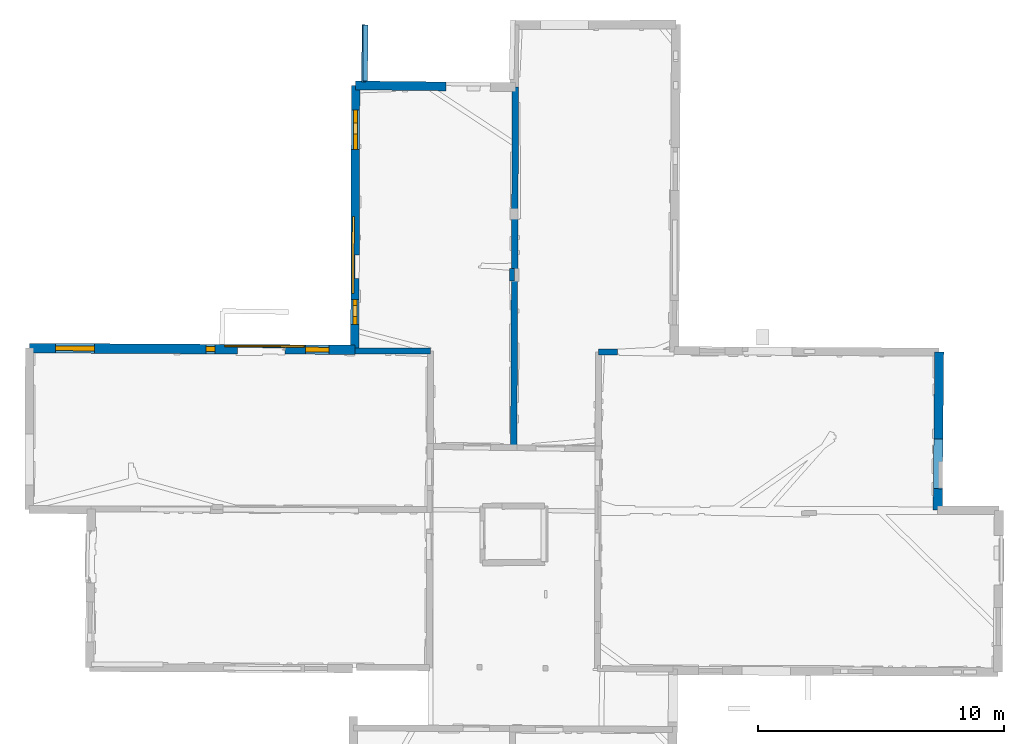
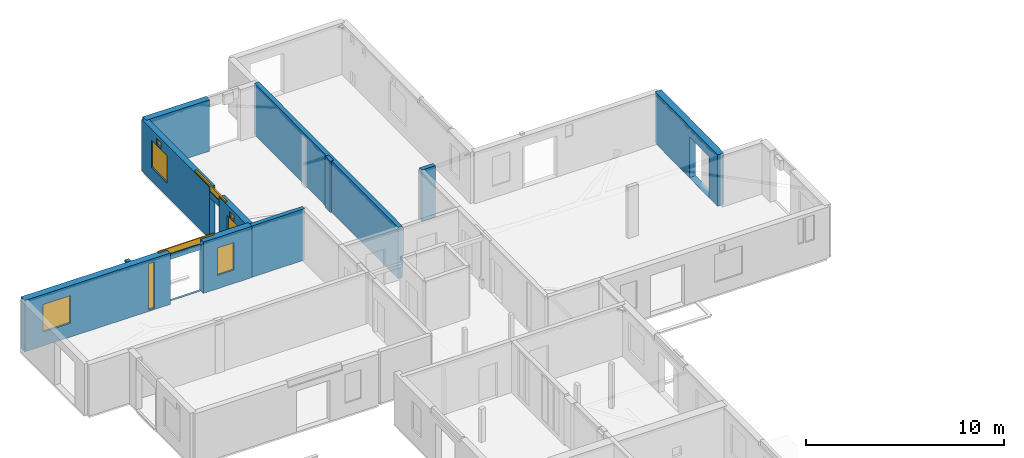
# One storey, part 10 of 17: 14 walls, 9 windows, 12 openings.
"""IFC2X3 building model written with IfcOpenShell, lengths in metres."""

from ifc_helpers import new_model, entity, si_unit, converted_unit, derived_unit, direction, frame, frame_2d, origin, origin_2d_with_axis, place, context, subcontext, project, spatial, polyline, rectangle, outline, extrude, source, transform, mapped, material, layer, layer_set, layer_usage, type_object, type_shapes, element, fill, save


model = new_model("IFC2X3")

# Units and contexts
model_context = context("Model", 3, precision=1e-05, world=origin(), true_north=direction((0.0, 1.0)))
body_context = subcontext(model_context, "Body", "Model", "MODEL_VIEW")
ifc_project = project(units=[si_unit("LENGTHUNIT", "METRE"), si_unit("AREAUNIT", "SQUARE_METRE"), si_unit("VOLUMEUNIT", "CUBIC_METRE"), converted_unit("PLANEANGLEUNIT", "DEGREE", entity("IfcRatioMeasure", 0.0174532925199433), si_unit("PLANEANGLEUNIT", "RADIAN"), dimensions=[0, 0, 0, 0, 0, 0, 0]), si_unit("MASSUNIT", "GRAM", prefix="KILO"), derived_unit("MASSDENSITYUNIT", [(si_unit("MASSUNIT", "GRAM", prefix="KILO"), 1), (si_unit("LENGTHUNIT", "METRE"), -3)]), derived_unit("MOMENTOFINERTIAUNIT", [(si_unit("LENGTHUNIT", "METRE"), 4)]), si_unit("TIMEUNIT", "SECOND"), si_unit("FREQUENCYUNIT", "HERTZ"), si_unit("THERMODYNAMICTEMPERATUREUNIT", "DEGREE_CELSIUS"), derived_unit("THERMALTRANSMITTANCEUNIT", [(si_unit("MASSUNIT", "GRAM", prefix="KILO"), 1), (si_unit("THERMODYNAMICTEMPERATUREUNIT", "KELVIN"), -1), (si_unit("TIMEUNIT", "SECOND"), -3)]), derived_unit("VOLUMETRICFLOWRATEUNIT", [(si_unit("LENGTHUNIT", "METRE"), 3), (si_unit("TIMEUNIT", "SECOND"), -1)]), si_unit("ELECTRICCURRENTUNIT", "AMPERE"), si_unit("ELECTRICVOLTAGEUNIT", "VOLT"), si_unit("POWERUNIT", "WATT"), si_unit("FORCEUNIT", "NEWTON", prefix="KILO"), si_unit("ILLUMINANCEUNIT", "LUX"), si_unit("LUMINOUSFLUXUNIT", "LUMEN"), si_unit("LUMINOUSINTENSITYUNIT", "CANDELA"), derived_unit("USERDEFINED", [(si_unit("MASSUNIT", "GRAM", prefix="KILO"), -1), (si_unit("LENGTHUNIT", "METRE"), -2), (si_unit("TIMEUNIT", "SECOND"), 3), (si_unit("LUMINOUSFLUXUNIT", "LUMEN"), 1)]), derived_unit("LINEARVELOCITYUNIT", [(si_unit("LENGTHUNIT", "METRE"), 1), (si_unit("TIMEUNIT", "SECOND"), -1)]), si_unit("PRESSUREUNIT", "PASCAL"), derived_unit("USERDEFINED", [(si_unit("LENGTHUNIT", "METRE"), -2), (si_unit("MASSUNIT", "GRAM", prefix="KILO"), 1), (si_unit("TIMEUNIT", "SECOND"), -2)]), derived_unit("LINEARFORCEUNIT", [(si_unit("MASSUNIT", "GRAM", prefix="KILO"), 1), (si_unit("LENGTHUNIT", "METRE"), 1), (si_unit("TIMEUNIT", "SECOND"), -2), (si_unit("LENGTHUNIT", "METRE"), -1)]), derived_unit("PLANARFORCEUNIT", [(si_unit("MASSUNIT", "GRAM", prefix="KILO"), 1), (si_unit("LENGTHUNIT", "METRE"), 1), (si_unit("TIMEUNIT", "SECOND"), -2), (si_unit("LENGTHUNIT", "METRE"), -2)])], contexts=[model_context])

# Site, building, storey
placement_1 = place(None, origin())
site = spatial("IfcSite", under=ifc_project, at=placement_1, CompositionType="ELEMENT")
building = spatial("IfcBuilding", under=site, at=placement_1, CompositionType="ELEMENT")
storey_placement = place(placement_1, frame((0.0, 0.0, 5.56662893295288)))
storey = spatial("IfcBuildingStorey", under=building, at=storey_placement, Name="Level 3", CompositionType="ELEMENT", Elevation=5.56662893295288)

# Walls
ifc_material_1 = material(Name="Default wall")
ifc_layer_1 = layer(ifc_material_1, 0.2)
ifc_layer_set_1 = layer_set([ifc_layer_1], Name="wall_thickness_0.2000")
ifc_layer_usage_1 = layer_usage(ifc_layer_set_1, "AXIS2", "POSITIVE", -0.1)
wall_type_1 = type_object("IfcWallType", Name="wall_thickness_0.2000", PredefinedType="STANDARD", material=ifc_layer_set_1)
wall_1_placement = place(storey_placement, frame((6.28764637032087, 67.4352917196023, 0.0), z_axis=(0.0, 0.0, 1.0), x_axis=(-0.0107159237013627, -0.999942582841248, 0.0)))
element("IfcWallStandardCase", 1, at=wall_1_placement, inside=storey, type_object=wall_type_1, material=ifc_layer_usage_1, Name="Wall:36", ObjectType="Wall", context=body_context, shape_type="SweptSolid", body=[
    extrude(outline(polyline([(0.520003612012755, -0.1), (0.520003612012755, 0.1), (0.0, 0.1), (0.0, -0.1), (0.520003612012755, -0.1)])), origin(), (0.0, 0.0, 1.0), 3.16489877700806),
])
placement_2 = place(placement_1, frame((0.0, 0.0, -2.2819995880127)))
wall_2_placement = place(placement_2, frame((0.333962232754324, 75.0506453341792, 0.0), z_axis=(0.0, 0.0, 1.0), x_axis=(0.00138742354692365, 0.999999037527487, 0.0)))
element("IfcWallStandardCase", 2, at=wall_2_placement, inside=storey, type_object=wall_type_1, material=ifc_layer_usage_1, Name="Wall:839", ObjectType="Wall", context=body_context, shape_type="SweptSolid", body=[
    extrude(outline(polyline([(2.26999882787788, -0.1), (2.26999882787788, 0.1), (0.0, 0.1), (0.0, -0.1), (2.26999882787788, -0.1)])), origin(), (0.0, 0.0, 1.0), 0.720746183395386),
])
placement_3 = place(placement_1, frame((0.0, 0.0, -1.68499946594238)))
wall_3_placement = place(placement_3, frame((0.271147242193165, 75.0066913158201, 0.0), z_axis=(0.0, 0.0, 1.0), x_axis=(0.0167813016414469, 0.999859184043043, 0.0)))
element("IfcWallStandardCase", 3, at=wall_3_placement, inside=storey, type_object=wall_type_1, material=ifc_layer_usage_1, Name="Wall:853", ObjectType="Wall", context=body_context, shape_type="SweptSolid", body=[
    extrude(outline(polyline([(2.31999832364346, -0.1), (2.31999832364346, 0.1), (0.0, 0.1), (0.0, -0.1), (2.31999832364346, -0.1)])), origin(), (0.0, 0.0, 1.0), 0.123746061325073),
])
ifc_layer_2 = layer(ifc_material_1, 0.239999994635582)
ifc_layer_set_2 = layer_set([ifc_layer_2], Name="wall_thickness_0.2400")
ifc_layer_usage_2 = layer_usage(ifc_layer_set_2, "AXIS2", "POSITIVE", -0.119999997317791)
wall_type_2 = type_object("IfcWallType", Name="wall_thickness_0.2400", PredefinedType="STANDARD", material=ifc_layer_set_2)
wall_4_placement = place(storey_placement, frame((-0.0902029865858402, 64.0753909123029, 0.0), z_axis=(0.0, 0.0, 1.0), x_axis=(0.999999872509444, -0.000504956528121127, 0.0)))
element("IfcWallStandardCase", 4, at=wall_4_placement, inside=storey, type_object=wall_type_2, material=ifc_layer_usage_2, Name="Wall:21", ObjectType="Wall", context=body_context, shape_type="SweptSolid", body=[
    extrude(outline(polyline([(3.07468405822243, -0.119999997317791), (3.07468405822243, 0.119999997317791), (0.0, 0.119999997317791), (0.0, -0.119999997317791), (3.07468405822243, -0.119999997317791)])), origin(), (0.0, 0.0, 1.0), 3.16489877700806),
])
wall_5_placement = place(storey_placement, frame((9.8043542696778, 64.0455676153873, 0.0), z_axis=(0.0, 0.0, 1.0), x_axis=(0.999999928116913, 0.000379165095462217, 0.0)))
element("IfcWallStandardCase", 5, at=wall_5_placement, inside=storey, type_object=wall_type_2, material=ifc_layer_usage_2, Name="Wall:34", ObjectType="Wall", context=body_context, shape_type="SweptSolid", body=[
    extrude(outline(polyline([(0.774680193320681, -0.119999997317791), (0.774680193320681, 0.119999997317791), (0.0, 0.119999997317791), (0.0, -0.119999997317791), (0.774680193320681, -0.119999997317791)])), origin(), (0.0, 0.0, 1.0), 3.16489877700806),
])
ifc_layer_3 = layer(ifc_material_1, 0.259999990463257)
ifc_layer_set_3 = layer_set([ifc_layer_3], Name="wall_thickness_0.2600")
ifc_layer_usage_3 = layer_usage(ifc_layer_set_3, "AXIS2", "POSITIVE", -0.129999995231628)
wall_type_3 = type_object("IfcWallType", Name="wall_thickness_0.2600", PredefinedType="STANDARD", material=ifc_layer_set_3)
wall_6_placement = place(storey_placement, frame((6.43128599709919, 74.7928656407587, 0.0), z_axis=(0.0, 0.0, 1.0), x_axis=(-0.00472347165307198, -0.999988844345547, 0.0)))
element("IfcWallStandardCase", 6, at=wall_6_placement, inside=storey, type_object=wall_type_3, material=ifc_layer_usage_3, Name="Wall:74", ObjectType="Wall", context=body_context, shape_type="SweptSolid", body=[
    extrude(outline(polyline([(14.6342994551391, -0.129999995231628), (14.6342994551391, 0.129999995231628), (0.0, 0.129999995231628), (0.0, -0.129999995231628), (14.6342994551391, -0.129999995231628)])), origin(), (0.0, 0.0, 1.0), 3.16489877700806),
])

# Wall, opening, window
ifc_layer_4 = layer(ifc_material_1, 0.379999995231628)
ifc_layer_set_4 = layer_set([ifc_layer_4], Name="wall_thickness_0.3800")
ifc_layer_usage_4 = layer_usage(ifc_layer_set_4, "AXIS2", "POSITIVE", -0.189999997615814)
wall_type_4 = type_object("IfcWallType", Name="wall_thickness_0.3800", PredefinedType="STANDARD", material=ifc_layer_set_4)
wall_7_placement = place(storey_placement, frame((-2.91485831987467, 64.1468712240695, 0.0), z_axis=(0.0, 0.0, 1.0), x_axis=(0.999984537881359, -0.00556093501180662, 0.0)))
wall_7 = element("IfcWallStandardCase", 7, at=wall_7_placement, inside=storey, type_object=wall_type_4, material=ifc_layer_usage_4, Name="Wall:64", ObjectType="Wall", context=body_context, shape_type="SweptSolid", body=[
    extrude(outline(polyline([(2.82487087270245, -0.189999997615814), (2.82487087270245, 0.189999997615814), (0.0, 0.189999997615814), (0.0, -0.189999997615814), (2.82487087270245, -0.189999997615814)])), origin(), (0.0, 0.0, 1.0), 3.16489877700806),
])
opening_1_placement = place(wall_7_placement, frame((0.820224171551078, -0.189999997615814, 0.830370903015137)))
opening_1 = element("IfcOpeningElement", 8, at=opening_1_placement, cuts=wall_7, Name="Opening : 965 x 1690 : 63", ObjectType="Opening", context=body_context, shape_type="SweptSolid", body=[
    extrude(rectangle(XDim=0.965, YDim=1.69, at=frame_2d((0.845, 0.4825), x_axis=(0.0, 1.0))), frame((0.0, 0.0, 0.0), z_axis=(0.0, 1.0, 0.0), x_axis=(0.0, 0.0, 1.0)), (0.0, 0.0, 1.0), 0.379999995231628),
])
ifc_material_2 = material(Name="Window Default")
window_style_1 = type_object("IfcWindowStyle", Name="Window : 965 x 1690mm", ConstructionType="NOTDEFINED", OperationType="NOTDEFINED", ParameterTakesPrecedence=False, Sizeable=False, material=ifc_material_2)
shared_shape_1 = source(origin(), body_context, "Body", "SweptSolid", [
    extrude(rectangle(XDim=0.189999997615814, YDim=0.965, at=origin_2d_with_axis()), frame((0.4825, 0.189999997615814, 0.0), z_axis=(0.0, 0.0, 1.0), x_axis=(0.0, 1.0, 0.0)), (0.0, 0.0, 1.0), 1.69),
])
type_shapes(window_style_1, [shared_shape_1])
window_1_placement = place(opening_1_placement, origin())
window_1 = element("IfcWindow", 9, at=window_1_placement, inside=storey, type_object=window_style_1, Name="Window : 965 x 1690mm : 40", ObjectType="Window : 965 x 1690mm", OverallHeight=1.69, OverallWidth=0.965, context=body_context, shape_type="MappedRepresentation", body=[
    mapped(shared_shape_1, transform((0.0, 0.0, 0.0), scale=1.0)),
])
fill(opening_1, window_1)

# Wall, openings, window
ifc_layer_5 = layer(ifc_material_1, 0.129999995231628)
ifc_layer_set_5 = layer_set([ifc_layer_5], Name="wall_thickness_0.1300")
ifc_layer_usage_5 = layer_usage(ifc_layer_set_5, "AXIS2", "POSITIVE", -0.0649999976158142)
wall_type_5 = type_object("IfcWallType", Name="wall_thickness_0.1300", PredefinedType="STANDARD", material=ifc_layer_set_5)
wall_8_placement = place(storey_placement, frame((-4.84394727717063, 64.2818576574933, 0.0), z_axis=(0.0, 0.0, 1.0), x_axis=(0.999996160460635, -0.00277111240991138, 0.0)))
wall_8 = element("IfcWallStandardCase", 10, at=wall_8_placement, inside=storey, type_object=wall_type_5, material=ifc_layer_usage_5, Name="Wall:68", ObjectType="Wall", context=body_context, shape_type="SweptSolid", body=[
    extrude(outline(polyline([(1.9299850656644, -0.0649999976158142), (1.9299850656644, 0.0649999976158142), (0.0, 0.0649999976158142), (0.0, -0.0649999976158142), (1.9299850656644, -0.0649999976158142)])), origin(), (0.0, 0.0, 1.0), 3.16489877700806),
])
opening_2_placement = place(wall_8_placement, frame((-0.034783283359304, -0.0649999976158142, 0.00537109375)))
element("IfcOpeningElement", 11, at=opening_2_placement, cuts=wall_8, Name="Opening : 1995 x 2545 : 65", ObjectType="Opening", context=body_context, shape_type="SweptSolid", body=[
    extrude(rectangle(XDim=1.995, YDim=2.545, at=frame_2d((1.2725, 0.9975), x_axis=(0.0, 1.0))), frame((0.0, 0.0, 0.0), z_axis=(0.0, 1.0, 0.0), x_axis=(0.0, 0.0, 1.0)), (0.0, 0.0, 1.0), 0.129999995231628),
])
opening_3_placement = place(wall_8_placement, frame((-0.53110497521868, -0.0649999976158142, 2.90537118911743)))
opening_3 = element("IfcOpeningElement", 12, at=opening_3_placement, cuts=wall_8, Name="Opening : 3230 x 350 : 66", ObjectType="Opening", context=body_context, shape_type="SweptSolid", body=[
    extrude(rectangle(XDim=3.23, YDim=0.35, at=frame_2d((0.175, 1.615), x_axis=(0.0, 1.0))), frame((0.0, 0.0, 0.0), z_axis=(0.0, 1.0, 0.0), x_axis=(0.0, 0.0, 1.0)), (0.0, 0.0, 1.0), 0.129999995231628),
])
window_style_2 = type_object("IfcWindowStyle", Name="Window : 3230 x 350mm", ConstructionType="NOTDEFINED", OperationType="NOTDEFINED", ParameterTakesPrecedence=False, Sizeable=False, material=ifc_material_2)
shared_shape_2 = source(origin(), body_context, "Body", "SweptSolid", [
    extrude(rectangle(XDim=0.0649999976158142, YDim=3.23, at=origin_2d_with_axis()), frame((1.615, 0.0649999976158142, 0.0), z_axis=(0.0, 0.0, 1.0), x_axis=(0.0, 1.0, 0.0)), (0.0, 0.0, 1.0), 0.35),
])
type_shapes(window_style_2, [shared_shape_2])
window_2_placement = place(opening_3_placement, origin())
window_2 = element("IfcWindow", 13, at=window_2_placement, inside=storey, type_object=window_style_2, Name="Window : 3230 x 350mm : 41", ObjectType="Window : 3230 x 350mm", OverallHeight=0.35, OverallWidth=3.23, context=body_context, shape_type="MappedRepresentation", body=[
    mapped(shared_shape_2, transform((0.0, 0.0, 0.0), scale=1.0)),
])
fill(opening_3, window_2)

# Wall, openings, windows
ifc_layer_6 = layer(ifc_material_1, 0.340000003576279)
ifc_layer_set_6 = layer_set([ifc_layer_6], Name="wall_thickness_0.3400")
ifc_layer_usage_6 = layer_usage(ifc_layer_set_6, "AXIS2", "POSITIVE", -0.170000001788139)
wall_type_6 = type_object("IfcWallType", Name="wall_thickness_0.3400", PredefinedType="STANDARD", material=ifc_layer_set_6)
wall_9_placement = place(storey_placement, frame((-0.0571033313504448, 74.8633852740018, 0.0), z_axis=(0.0, 0.0, 1.0), x_axis=(-0.00306815945181974, -0.999995293187712, 0.0)))
wall_9 = element("IfcWallStandardCase", 14, at=wall_9_placement, inside=storey, type_object=wall_type_6, material=ifc_layer_usage_6, Name="Wall:19", ObjectType="Wall", context=body_context, shape_type="SweptSolid", body=[
    extrude(outline(polyline([(6.87837405002019, -0.170000001788139), (6.87837405002019, 0.170000001788139), (0.0, 0.170000001788139), (0.0, -0.170000001788139), (6.87837405002019, -0.170000001788139)])), origin(), (0.0, 0.0, 1.0), 3.16489877700806),
])
opening_4_placement = place(wall_9_placement, frame((0.988415602780925, -0.170000001788139, 0.805370807647705)))
opening_4 = element("IfcOpeningElement", 15, at=opening_4_placement, cuts=wall_9, Name="Opening : 1620 x 1705 : 19", ObjectType="Opening", context=body_context, shape_type="SweptSolid", body=[
    extrude(rectangle(XDim=1.62, YDim=1.705, at=frame_2d((0.8525, 0.81), x_axis=(0.0, 1.0))), frame((0.0, 0.0, 0.0), z_axis=(0.0, 1.0, 0.0), x_axis=(0.0, 0.0, 1.0)), (0.0, 0.0, 1.0), 0.340000003576279),
])
opening_5_placement = place(wall_9_placement, frame((1.51938581435418, -0.170000001788139, 2.56237077713013)))
opening_5 = element("IfcOpeningElement", 16, at=opening_5_placement, cuts=wall_9, Name="Opening : 445 x 375 : 20", ObjectType="Opening", context=body_context, shape_type="SweptSolid", body=[
    extrude(rectangle(XDim=0.445, YDim=0.375, at=frame_2d((0.1875, 0.2225), x_axis=(0.0, 1.0))), frame((0.0, 0.0, 0.0), z_axis=(0.0, 1.0, 0.0), x_axis=(0.0, 0.0, 1.0)), (0.0, 0.0, 1.0), 0.340000003576279),
])
window_style_3 = type_object("IfcWindowStyle", Name="Window : 1620 x 1705mm", ConstructionType="NOTDEFINED", OperationType="NOTDEFINED", ParameterTakesPrecedence=False, Sizeable=False, material=ifc_material_2)
shared_shape_3 = source(origin(), body_context, "Body", "SweptSolid", [
    extrude(rectangle(XDim=0.170000001788139, YDim=1.62, at=origin_2d_with_axis()), frame((0.81, 0.170000001788139, 0.0), z_axis=(0.0, 0.0, 1.0), x_axis=(0.0, 1.0, 0.0)), (0.0, 0.0, 1.0), 1.705),
])
type_shapes(window_style_3, [shared_shape_3])
window_3_placement = place(opening_4_placement, origin())
window_3 = element("IfcWindow", 17, at=window_3_placement, inside=storey, type_object=window_style_3, Name="Window : 1620 x 1705mm : 10", ObjectType="Window : 1620 x 1705mm", OverallHeight=1.705, OverallWidth=1.62, context=body_context, shape_type="MappedRepresentation", body=[
    mapped(shared_shape_3, transform((0.0, 0.0, 0.0), scale=1.0)),
])
fill(opening_4, window_3)
window_style_4 = type_object("IfcWindowStyle", Name="Window : 445 x 375mm", ConstructionType="NOTDEFINED", OperationType="NOTDEFINED", ParameterTakesPrecedence=False, Sizeable=False, material=ifc_material_2)
shared_shape_4 = source(origin(), body_context, "Body", "SweptSolid", [
    extrude(rectangle(XDim=0.170000001788139, YDim=0.445, at=origin_2d_with_axis()), frame((0.2225, 0.170000001788139, 0.0), z_axis=(0.0, 0.0, 1.0), x_axis=(0.0, 1.0, 0.0)), (0.0, 0.0, 1.0), 0.375),
])
type_shapes(window_style_4, [shared_shape_4])
window_4_placement = place(opening_5_placement, origin())
window_4 = element("IfcWindow", 18, at=window_4_placement, inside=storey, type_object=window_style_4, Name="Window : 445 x 375mm : 11", ObjectType="Window : 445 x 375mm", OverallHeight=0.375, OverallWidth=0.445, context=body_context, shape_type="MappedRepresentation", body=[
    mapped(shared_shape_4, transform((0.0, 0.0, 0.0), scale=1.0)),
])
fill(opening_5, window_4)

wall_10_placement = place(storey_placement, frame((-0.0811546250830022, 67.0244036449901, 0.0), z_axis=(0.0, 0.0, 1.0), x_axis=(-0.00306815841024347, -0.999995293190908, 0.0)))
wall_10 = element("IfcWallStandardCase", 19, at=wall_10_placement, inside=storey, type_object=wall_type_6, material=ifc_layer_usage_6, Name="Wall:20", ObjectType="Wall", context=body_context, shape_type="SweptSolid", body=[
    extrude(outline(polyline([(2.94903426628349, -0.170000001788139), (2.94903426628349, 0.170000001788139), (0.0, 0.170000001788139), (0.0, -0.170000001788139), (2.94903426628349, -0.170000001788139)])), origin(), (0.0, 0.0, 1.0), 3.16489877700806),
])
opening_6_placement = place(wall_10_placement, frame((0.849392120459991, -0.170000001788139, 0.810370922088623)))
opening_6 = element("IfcOpeningElement", 20, at=opening_6_placement, cuts=wall_10, Name="Opening : 1020 x 1725 : 21", ObjectType="Opening", context=body_context, shape_type="SweptSolid", body=[
    extrude(rectangle(XDim=1.02, YDim=1.725, at=frame_2d((0.8625, 0.51), x_axis=(0.0, 1.0))), frame((0.0, 0.0, 0.0), z_axis=(0.0, 1.0, 0.0), x_axis=(0.0, 0.0, 1.0)), (0.0, 0.0, 1.0), 0.340000003576279),
])
opening_7_placement = place(wall_10_placement, frame((1.09937040884512, -0.170000001788139, 2.56137132644653)))
opening_7 = element("IfcOpeningElement", 21, at=opening_7_placement, cuts=wall_10, Name="Opening : 440 x 370 : 22", ObjectType="Opening", context=body_context, shape_type="SweptSolid", body=[
    extrude(rectangle(XDim=0.44, YDim=0.37, at=frame_2d((0.185, 0.22), x_axis=(0.0, 1.0))), frame((0.0, 0.0, 0.0), z_axis=(0.0, 1.0, 0.0), x_axis=(0.0, 0.0, 1.0)), (0.0, 0.0, 1.0), 0.340000003576279),
])
window_style_5 = type_object("IfcWindowStyle", Name="Window : 1020 x 1725mm", ConstructionType="NOTDEFINED", OperationType="NOTDEFINED", ParameterTakesPrecedence=False, Sizeable=False, material=ifc_material_2)
shared_shape_5 = source(origin(), body_context, "Body", "SweptSolid", [
    extrude(rectangle(XDim=0.170000001788139, YDim=1.02, at=origin_2d_with_axis()), frame((0.51, 0.170000001788139, 0.0), z_axis=(0.0, 0.0, 1.0), x_axis=(0.0, 1.0, 0.0)), (0.0, 0.0, 1.0), 1.725),
])
type_shapes(window_style_5, [shared_shape_5])
window_5_placement = place(opening_6_placement, origin())
window_5 = element("IfcWindow", 22, at=window_5_placement, inside=storey, type_object=window_style_5, Name="Window : 1020 x 1725mm : 12", ObjectType="Window : 1020 x 1725mm", OverallHeight=1.725, OverallWidth=1.02, context=body_context, shape_type="MappedRepresentation", body=[
    mapped(shared_shape_5, transform((0.0, 0.0, 0.0), scale=1.0)),
])
fill(opening_6, window_5)
window_style_6 = type_object("IfcWindowStyle", Name="Window : 440 x 370mm", ConstructionType="NOTDEFINED", OperationType="NOTDEFINED", ParameterTakesPrecedence=False, Sizeable=False, material=ifc_material_2)
shared_shape_6 = source(origin(), body_context, "Body", "SweptSolid", [
    extrude(rectangle(XDim=0.170000001788139, YDim=0.44, at=origin_2d_with_axis()), frame((0.22, 0.170000001788139, 0.0), z_axis=(0.0, 0.0, 1.0), x_axis=(0.0, 1.0, 0.0)), (0.0, 0.0, 1.0), 0.37),
])
type_shapes(window_style_6, [shared_shape_6])
window_6_placement = place(opening_7_placement, origin())
window_6 = element("IfcWindow", 23, at=window_6_placement, inside=storey, type_object=window_style_6, Name="Window : 440 x 370mm : 13", ObjectType="Window : 440 x 370mm", OverallHeight=0.37, OverallWidth=0.44, context=body_context, shape_type="MappedRepresentation", body=[
    mapped(shared_shape_6, transform((0.0, 0.0, 0.0), scale=1.0)),
])
fill(opening_7, window_6)

# Wall, opening
ifc_layer_7 = layer(ifc_material_1, 0.370000004768372)
ifc_layer_set_7 = layer_set([ifc_layer_7], Name="wall_thickness_0.3700")
ifc_layer_usage_7 = layer_usage(ifc_layer_set_7, "AXIS2", "POSITIVE", -0.185000002384186)
wall_type_7 = type_object("IfcWallType", Name="wall_thickness_0.3700", PredefinedType="STANDARD", material=ifc_layer_set_7)
wall_11_placement = place(storey_placement, frame((23.6337286399068, 64.0351960615015, 0.0), z_axis=(0.0, 0.0, 1.0), x_axis=(-0.00974244291627919, -0.999952541276846, 0.0)))
wall_11 = element("IfcWallStandardCase", 24, at=wall_11_placement, inside=storey, type_object=wall_type_7, material=ifc_layer_usage_7, Name="Wall:123", ObjectType="Wall", context=body_context, shape_type="SweptSolid", body=[
    extrude(outline(polyline([(6.41405409764193, -0.185000002384186), (6.41405409764193, 0.185000002384186), (0.0, 0.185000002384186), (0.0, -0.185000002384186), (6.41405409764193, -0.185000002384186)])), origin(), (0.0, 0.0, 1.0), 3.16489877700806),
])
opening_8_placement = place(wall_11_placement, frame((3.52508015315699, -0.185000002384186, 0.00537109375)))
element("IfcOpeningElement", 25, at=opening_8_placement, cuts=wall_11, Name="Opening : 2020 x 2520 : 115", ObjectType="Opening", context=body_context, shape_type="SweptSolid", body=[
    extrude(rectangle(XDim=2.02, YDim=2.52, at=frame_2d((1.26, 1.01), x_axis=(0.0, 1.0))), frame((0.0, 0.0, 0.0), z_axis=(0.0, 1.0, 0.0), x_axis=(0.0, 0.0, 1.0)), (0.0, 0.0, 1.0), 0.370000004768372),
])

# Wall, openings, windows
ifc_layer_8 = layer(ifc_material_1, 0.389999985694885)
ifc_layer_set_8 = layer_set([ifc_layer_8], Name="wall_thickness_0.3900")
ifc_layer_usage_8 = layer_usage(ifc_layer_set_8, "AXIS2", "POSITIVE", -0.194999992847443)
wall_type_8 = type_object("IfcWallType", Name="wall_thickness_0.3900", PredefinedType="STANDARD", material=ifc_layer_set_8)
wall_12_placement = place(storey_placement, frame((-13.2971284057832, 64.1996410872796, 0.0), z_axis=(0.0, 0.0, 1.0), x_axis=(0.999984501803003, -0.00556741895312955, 0.0)))
wall_12 = element("IfcWallStandardCase", 26, at=wall_12_placement, inside=storey, type_object=wall_type_8, material=ifc_layer_usage_8, Name="Wall:63", ObjectType="Wall", context=body_context, shape_type="SweptSolid", body=[
    extrude(outline(polyline([(8.45240961115344, -0.194999992847443), (8.45240961115344, 0.194999992847443), (0.0, 0.194999992847443), (0.0, -0.194999992847443), (8.45240961115344, -0.194999992847443)])), origin(), (0.0, 0.0, 1.0), 3.16489877700806),
])
opening_9_placement = place(wall_12_placement, frame((1.05262416117311, -0.194999992847443, 0.85037088394165)))
opening_9 = element("IfcOpeningElement", 27, at=opening_9_placement, cuts=wall_12, Name="Opening : 1590 x 1705 : 61", ObjectType="Opening", context=body_context, shape_type="SweptSolid", body=[
    extrude(rectangle(XDim=1.59, YDim=1.705, at=frame_2d((0.8525, 0.795), x_axis=(0.0, 1.0))), frame((0.0, 0.0, 0.0), z_axis=(0.0, 1.0, 0.0), x_axis=(0.0, 0.0, 1.0)), (0.0, 0.0, 1.0), 0.389999985694885),
])
opening_10_placement = place(wall_12_placement, frame((7.17482747945436, -0.194999992847443, 0.0803709030151367)))
opening_10 = element("IfcOpeningElement", 28, at=opening_10_placement, cuts=wall_12, Name="Opening : 365 x 2860 : 62", ObjectType="Opening", context=body_context, shape_type="SweptSolid", body=[
    extrude(rectangle(XDim=0.365, YDim=2.86, at=frame_2d((1.43, 0.1825), x_axis=(0.0, 1.0))), frame((0.0, 0.0, 0.0), z_axis=(0.0, 1.0, 0.0), x_axis=(0.0, 0.0, 1.0)), (0.0, 0.0, 1.0), 0.389999985694885),
])
window_style_7 = type_object("IfcWindowStyle", Name="Window : 1590 x 1705mm", ConstructionType="NOTDEFINED", OperationType="NOTDEFINED", ParameterTakesPrecedence=False, Sizeable=False, material=ifc_material_2)
shared_shape_7 = source(origin(), body_context, "Body", "SweptSolid", [
    extrude(rectangle(XDim=0.194999992847443, YDim=1.59, at=origin_2d_with_axis()), frame((0.795, 0.194999992847443, 0.0), z_axis=(0.0, 0.0, 1.0), x_axis=(0.0, 1.0, 0.0)), (0.0, 0.0, 1.0), 1.705),
])
type_shapes(window_style_7, [shared_shape_7])
window_7_placement = place(opening_9_placement, origin())
window_7 = element("IfcWindow", 29, at=window_7_placement, inside=storey, type_object=window_style_7, Name="Window : 1590 x 1705mm : 38", ObjectType="Window : 1590 x 1705mm", OverallHeight=1.705, OverallWidth=1.59, context=body_context, shape_type="MappedRepresentation", body=[
    mapped(shared_shape_7, transform((0.0, 0.0, 0.0), scale=1.0)),
])
fill(opening_9, window_7)
window_style_8 = type_object("IfcWindowStyle", Name="Window : 365 x 2860mm", ConstructionType="NOTDEFINED", OperationType="NOTDEFINED", ParameterTakesPrecedence=False, Sizeable=False, material=ifc_material_2)
shared_shape_8 = source(origin(), body_context, "Body", "SweptSolid", [
    extrude(rectangle(XDim=0.194999992847443, YDim=0.365, at=origin_2d_with_axis()), frame((0.1825, 0.194999992847443, 0.0), z_axis=(0.0, 0.0, 1.0), x_axis=(0.0, 1.0, 0.0)), (0.0, 0.0, 1.0), 2.86),
])
type_shapes(window_style_8, [shared_shape_8])
window_8_placement = place(opening_10_placement, origin())
window_8 = element("IfcWindow", 30, at=window_8_placement, inside=storey, type_object=window_style_8, Name="Window : 365 x 2860mm : 39", ObjectType="Window : 365 x 2860mm", OverallHeight=2.86, OverallWidth=0.365, context=body_context, shape_type="MappedRepresentation", body=[
    mapped(shared_shape_8, transform((0.0, 0.0, 0.0), scale=1.0)),
])
fill(opening_10, window_8)

# Wall
ifc_layer_9 = layer(ifc_material_1, 0.360000014305115)
ifc_layer_set_9 = layer_set([ifc_layer_9], Name="wall_thickness_0.3600")
ifc_layer_usage_9 = layer_usage(ifc_layer_set_9, "AXIS2", "POSITIVE", -0.180000007152557)
wall_type_9 = type_object("IfcWallType", Name="wall_thickness_0.3600", PredefinedType="STANDARD", material=ifc_layer_set_9)
wall_13_placement = place(storey_placement, frame((-0.0571031738009441, 74.8633913645741, 0.0), z_axis=(0.0, 0.0, 1.0), x_axis=(0.999940881091828, -0.0108735606541226, 0.0)))
element("IfcWallStandardCase", 31, at=wall_13_placement, inside=storey, type_object=wall_type_9, material=ifc_layer_usage_9, Name="Wall:119", ObjectType="Wall", context=body_context, shape_type="SweptSolid", body=[
    extrude(outline(polyline([(3.66680401099301, -0.180000007152557), (3.66680401099301, 0.180000007152557), (0.0, 0.180000007152557), (0.0, -0.180000007152557), (3.66680401099301, -0.180000007152557)])), origin(), (0.0, 0.0, 1.0), 3.16489877700806),
])

# Wall, openings, window
ifc_layer_10 = layer(ifc_material_1, 0.170000001788139)
ifc_layer_set_10 = layer_set([ifc_layer_10], Name="wall_thickness_0.1700")
ifc_layer_usage_10 = layer_usage(ifc_layer_set_10, "AXIS2", "POSITIVE", -0.0850000008940697)
wall_type_10 = type_object("IfcWallType", Name="wall_thickness_0.1700", PredefinedType="STANDARD", material=ifc_layer_set_10)
wall_14_placement = place(storey_placement, frame((-0.15917589741116, 67.9848426474701, 0.0), z_axis=(0.0, 0.0, 1.0), x_axis=(-0.00810468754581931, -0.999967156480544, 0.0)))
wall_14 = element("IfcWallStandardCase", 32, at=wall_14_placement, inside=storey, type_object=wall_type_10, material=ifc_layer_usage_10, Name="Wall:86", ObjectType="Wall", context=body_context, shape_type="SweptSolid", body=[
    extrude(outline(polyline([(0.960633357220983, -0.0850000008940697), (0.960633357220983, 0.0850000008940697), (0.0, 0.0850000008940697), (0.0, -0.0850000008940697), (0.960633357220983, -0.0850000008940697)])), origin(), (0.0, 0.0, 1.0), 3.16489877700806),
])
opening_11_placement = place(wall_14_placement, frame((-0.989954081824339, -0.0850000008940697, 0.00537109375)))
element("IfcOpeningElement", 33, at=opening_11_placement, cuts=wall_14, Name="Opening : 1995 x 2545 : 78", ObjectType="Opening", context=body_context, shape_type="SweptSolid", body=[
    extrude(rectangle(XDim=1.995, YDim=2.545, at=frame_2d((1.2725, 0.9975), x_axis=(0.0, 1.0))), frame((0.0, 0.0, 0.0), z_axis=(0.0, 1.0, 0.0), x_axis=(0.0, 0.0, 1.0)), (0.0, 0.0, 1.0), 0.170000001788139),
])
opening_12_placement = place(wall_14_placement, frame((-1.55494456195563, -0.0850000008940697, 2.92537069320679)))
opening_12 = element("IfcOpeningElement", 34, at=opening_12_placement, cuts=wall_14, Name="Opening : 3130 x 330 : 79", ObjectType="Opening", context=body_context, shape_type="SweptSolid", body=[
    extrude(rectangle(XDim=3.13, YDim=0.33, at=frame_2d((0.165, 1.565), x_axis=(0.0, 1.0))), frame((0.0, 0.0, 0.0), z_axis=(0.0, 1.0, 0.0), x_axis=(0.0, 0.0, 1.0)), (0.0, 0.0, 1.0), 0.170000001788139),
])
window_style_9 = type_object("IfcWindowStyle", Name="Window : 3130 x 330mm", ConstructionType="NOTDEFINED", OperationType="NOTDEFINED", ParameterTakesPrecedence=False, Sizeable=False, material=ifc_material_2)
shared_shape_9 = source(origin(), body_context, "Body", "SweptSolid", [
    extrude(rectangle(XDim=0.0850000008940697, YDim=3.13, at=origin_2d_with_axis()), frame((1.565, 0.0850000008940697, 0.0), z_axis=(0.0, 0.0, 1.0), x_axis=(0.0, 1.0, 0.0)), (0.0, 0.0, 1.0), 0.33),
])
type_shapes(window_style_9, [shared_shape_9])
window_9_placement = place(opening_12_placement, origin())
window_9 = element("IfcWindow", 35, at=window_9_placement, inside=storey, type_object=window_style_9, Name="Window : 3130 x 330mm : 48", ObjectType="Window : 3130 x 330mm", OverallHeight=0.33, OverallWidth=3.13, context=body_context, shape_type="MappedRepresentation", body=[
    mapped(shared_shape_9, transform((0.0, 0.0, 0.0), scale=1.0)),
])
fill(opening_12, window_9)

save(model, "model.ifc")
